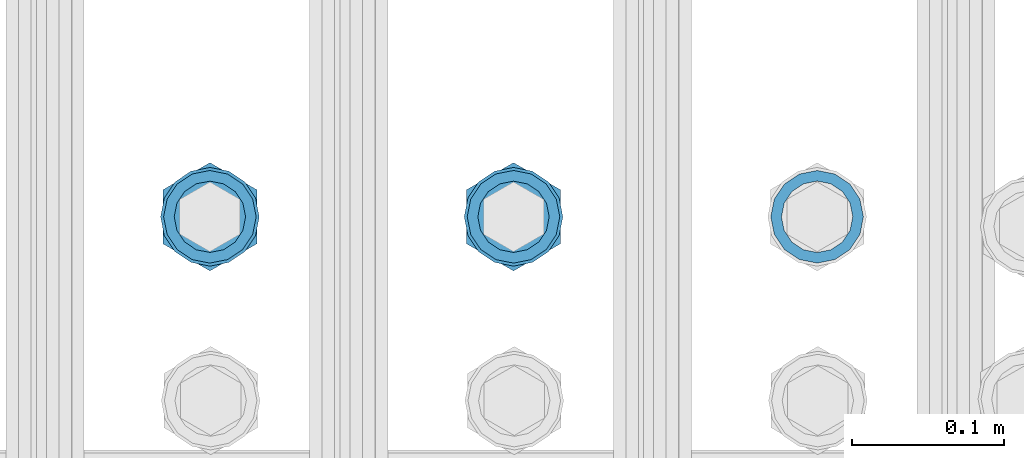
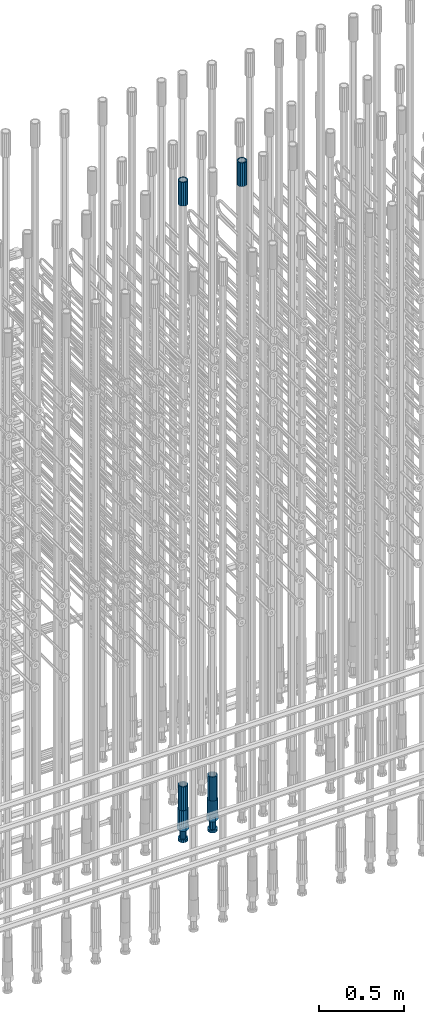
# One storey, part 58 of 177: 6 beams.
"""IFC2X3 building model written with IfcOpenShell, lengths in millimetres."""

from ifc_helpers import new_model, si_unit, frame, origin_with_axes, place, context, subcontext, project, spatial, faceted_brep, material, type_object, element, save


model = new_model("IFC2X3")

# Units and contexts
model_context_1 = context("Model", 3, precision=1e-05, world=origin_with_axes())
model_context_2 = context("Model", 3, precision=1e-05, world=origin_with_axes())
body_context = subcontext(model_context_2, "Body", "Model", "MODEL_VIEW")
ifc_project = project(units=[si_unit("LENGTHUNIT", "METRE", prefix="MILLI"), si_unit("AREAUNIT", "SQUARE_METRE"), si_unit("VOLUMEUNIT", "CUBIC_METRE"), si_unit("MASSUNIT", "GRAM", prefix="KILO"), si_unit("TIMEUNIT", "SECOND"), si_unit("PLANEANGLEUNIT", "RADIAN"), si_unit("SOLIDANGLEUNIT", "STERADIAN"), si_unit("THERMODYNAMICTEMPERATUREUNIT", "DEGREE_CELSIUS"), si_unit("LUMINOUSINTENSITYUNIT", "LUMEN")], contexts=[model_context_1])

# Site, building, storey
site_placement = place(None, origin_with_axes())
site = spatial("IfcSite", under=ifc_project, at=site_placement, CompositionType="ELEMENT")
building_placement = place(site_placement, origin_with_axes())
building = spatial("IfcBuilding", under=site, at=building_placement, Name="Undefined", CompositionType="ELEMENT")
storey_placement = place(building_placement, origin_with_axes())
storey = spatial("IfcBuildingStorey", under=building, at=storey_placement, Name="Undefined", CompositionType="ELEMENT", Elevation=0.0)

# Beams
ifc_material = material(Name="STEEL/S275")
beam_type_1 = type_object("IfcBeamType", PredefinedType="NOTDEFINED")
beam_1_placement = place(storey_placement, frame((2032635.50306268, 6205277.49272666, 23229.9858194793), z_axis=(1.0, 0.0, 0.0), x_axis=(0.0, 0.0, 1.0)))
element("IfcBeam", 1, at=beam_1_placement, inside=storey, type_object=beam_type_1, material=ifc_material, Name="AG40N", context=body_context, shape_type="Brep", body=[
    faceted_brep([(0.0, -23.5000000001164, -9.31322574615479e-10), (0.0, -21.7111690140155, 8.99306066054851), (170.0, -21.7111690140155, 8.99306066054851), (170.0, -23.5, 0.0), (0.0, -16.6170093578839, 16.6170093575493), (170.0, -16.6170093578839, 16.6170093575493), (0.0, -8.99306066057943, 21.7111690137535), (170.0, -8.99306066057943, 21.7111690137535), (0.0, 1.16415321826935e-10, 23.5), (170.0, 0.0, 23.5), (0.0, 8.99306066057943, 21.7111690137535), (170.0, 8.99306066057943, 21.7111690137535), (0.0, 16.6170093578839, 16.6170093575493), (170.0, 16.6170093578839, 16.6170093575493), (0.0, 21.7111690140155, 8.99306066054851), (170.0, 21.7111690140155, 8.99306066054851), (0.0, 23.5000000001164, -9.31322574615479e-10), (170.0, 23.5, 0.0), (0.0, 21.7111690140155, -8.99306066054851), (170.0, 21.7111690140155, -8.99306066054851), (0.0, 16.6170093578839, -16.6170093575493), (170.0, 16.6170093578839, -16.6170093575493), (0.0, 8.99306066057943, -21.7111690137535), (170.0, 8.99306066057943, -21.7111690137535), (0.0, 1.16415321826935e-10, -23.5000000009313), (170.0, 0.0, -23.5), (0.0, -8.99306066057943, -21.7111690137535), (170.0, -8.99306066057943, -21.7111690137535), (0.0, -16.6170093578839, -16.6170093575493), (170.0, -16.6170093578839, -16.6170093575493), (0.0, -21.7111690140155, -8.99306066054851), (170.0, -21.7111690140155, -8.99306066054851), (0.0, -30.5, 0.0), (0.0, -28.1783257415937, -11.6718446873128), (170.0, -28.1783257415937, -11.6718446873128), (170.0, -30.5, 0.0), (0.0, -21.5667568261888, -21.5667568258941), (170.0, -21.5667568261888, -21.5667568258941), (0.0, -11.6718446871346, -28.1783257415518), (170.0, -11.6718446871346, -28.1783257415518), (0.0, 0.0, -30.5), (170.0, 0.0, -30.5), (0.0, 11.6718446871346, -28.1783257415518), (170.0, 11.6718446871346, -28.1783257415518), (0.0, 21.5667568261888, -21.5667568258941), (170.0, 21.5667568261888, -21.5667568258941), (0.0, 28.1783257415937, -11.6718446873128), (170.0, 28.1783257415937, -11.6718446873128), (0.0, 30.5, 0.0), (170.0, 30.5, 0.0), (0.0, 28.1783257415937, 11.6718446873128), (170.0, 28.1783257415937, 11.6718446873128), (0.0, 21.5667568261888, 21.5667568258941), (170.0, 21.5667568261888, 21.5667568258941), (0.0, 11.6718446871346, 28.1783257415518), (170.0, 11.6718446871346, 28.1783257415518), (0.0, 0.0, 30.5), (170.0, 0.0, 30.5), (0.0, -11.6718446871346, 28.1783257415518), (170.0, -11.6718446871346, 28.1783257415518), (0.0, -21.5667568261888, 21.5667568258941), (170.0, -21.5667568261888, 21.5667568258941), (0.0, -28.1783257415937, 11.6718446873128), (170.0, -28.1783257415937, 11.6718446873128)], [[[0, 1, 2, 3]], [[1, 4, 5, 2]], [[4, 6, 7, 5]], [[6, 8, 9, 7]], [[8, 10, 11, 9]], [[10, 12, 13, 11]], [[12, 14, 15, 13]], [[14, 16, 17, 15]], [[16, 18, 19, 17]], [[18, 20, 21, 19]], [[20, 22, 23, 21]], [[22, 24, 25, 23]], [[24, 26, 27, 25]], [[26, 28, 29, 27]], [[28, 30, 31, 29]], [[30, 0, 3, 31]], [[32, 33, 34, 35]], [[33, 36, 37, 34]], [[36, 38, 39, 37]], [[38, 40, 41, 39]], [[40, 42, 43, 41]], [[42, 44, 45, 43]], [[44, 46, 47, 45]], [[46, 48, 49, 47]], [[48, 50, 51, 49]], [[50, 52, 53, 51]], [[52, 54, 55, 53]], [[54, 56, 57, 55]], [[56, 58, 59, 57]], [[58, 60, 61, 59]], [[60, 62, 63, 61]], [[62, 32, 35, 63]], [[37, 39, 41, 43, 45, 47, 49, 51, 53, 55, 57, 59, 61, 63, 35, 34], [5, 7, 9, 11, 13, 15, 17, 19, 21, 23, 25, 27, 29, 31, 3, 2]], [[62, 60, 58, 56, 54, 52, 50, 48, 46, 44, 42, 40, 38, 36, 33, 32], [30, 28, 26, 24, 22, 20, 18, 16, 14, 12, 10, 8, 6, 4, 1, 0]]]),
])
beam_2_placement = place(storey_placement, frame((2032235.5030627, 6205277.49272666, 19060.966800425), z_axis=(-1.0, 0.0, 0.0), x_axis=(0.0, 0.0, -1.0)))
element("IfcBeam", 2, at=beam_2_placement, inside=storey, type_object=beam_type_1, material=ifc_material, Name="AG40N", context=body_context, shape_type="Brep", body=[
    faceted_brep([(0.0, -23.5000000001164, -9.31322574615479e-10), (0.0, -21.7111690140155, 8.99306066054851), (170.0, -21.7111690140155, 8.99306066054851), (170.0, -23.5, 0.0), (0.0, -16.6170093578839, 16.6170093575493), (170.0, -16.6170093578839, 16.6170093575493), (0.0, -8.99306066057943, 21.7111690137535), (170.0, -8.99306066057943, 21.7111690137535), (0.0, 1.16415321826935e-10, 23.5), (170.0, 0.0, 23.5), (0.0, 8.99306066057943, 21.7111690137535), (170.0, 8.99306066057943, 21.7111690137535), (0.0, 16.6170093578839, 16.6170093575493), (170.0, 16.6170093578839, 16.6170093575493), (0.0, 21.7111690140155, 8.99306066054851), (170.0, 21.7111690140155, 8.99306066054851), (0.0, 23.5000000001164, -9.31322574615479e-10), (170.0, 23.5, 0.0), (0.0, 21.7111690140155, -8.99306066054851), (170.0, 21.7111690140155, -8.99306066054851), (0.0, 16.6170093578839, -16.6170093575493), (170.0, 16.6170093578839, -16.6170093575493), (0.0, 8.99306066057943, -21.7111690137535), (170.0, 8.99306066057943, -21.7111690137535), (0.0, 1.16415321826935e-10, -23.5000000009313), (170.0, 0.0, -23.5), (0.0, -8.99306066057943, -21.7111690137535), (170.0, -8.99306066057943, -21.7111690137535), (0.0, -16.6170093578839, -16.6170093575493), (170.0, -16.6170093578839, -16.6170093575493), (0.0, -21.7111690140155, -8.99306066054851), (170.0, -21.7111690140155, -8.99306066054851), (0.0, -30.5, 0.0), (0.0, -28.1783257415937, -11.6718446873128), (170.0, -28.1783257415937, -11.6718446873128), (170.0, -30.5, 0.0), (0.0, -21.5667568261888, -21.5667568258941), (170.0, -21.5667568261888, -21.5667568258941), (0.0, -11.6718446871346, -28.1783257415518), (170.0, -11.6718446871346, -28.1783257415518), (0.0, 0.0, -30.5), (170.0, 0.0, -30.5), (0.0, 11.6718446871346, -28.1783257415518), (170.0, 11.6718446871346, -28.1783257415518), (0.0, 21.5667568261888, -21.5667568258941), (170.0, 21.5667568261888, -21.5667568258941), (0.0, 28.1783257415937, -11.6718446873128), (170.0, 28.1783257415937, -11.6718446873128), (0.0, 30.5, 0.0), (170.0, 30.5, 0.0), (0.0, 28.1783257415937, 11.6718446873128), (170.0, 28.1783257415937, 11.6718446873128), (0.0, 21.5667568261888, 21.5667568258941), (170.0, 21.5667568261888, 21.5667568258941), (0.0, 11.6718446871346, 28.1783257415518), (170.0, 11.6718446871346, 28.1783257415518), (0.0, 0.0, 30.5), (170.0, 0.0, 30.5), (0.0, -11.6718446871346, 28.1783257415518), (170.0, -11.6718446871346, 28.1783257415518), (0.0, -21.5667568261888, 21.5667568258941), (170.0, -21.5667568261888, 21.5667568258941), (0.0, -28.1783257415937, 11.6718446873128), (170.0, -28.1783257415937, 11.6718446873128)], [[[0, 1, 2, 3]], [[1, 4, 5, 2]], [[4, 6, 7, 5]], [[6, 8, 9, 7]], [[8, 10, 11, 9]], [[10, 12, 13, 11]], [[12, 14, 15, 13]], [[14, 16, 17, 15]], [[16, 18, 19, 17]], [[18, 20, 21, 19]], [[20, 22, 23, 21]], [[22, 24, 25, 23]], [[24, 26, 27, 25]], [[26, 28, 29, 27]], [[28, 30, 31, 29]], [[30, 0, 3, 31]], [[32, 33, 34, 35]], [[33, 36, 37, 34]], [[36, 38, 39, 37]], [[38, 40, 41, 39]], [[40, 42, 43, 41]], [[42, 44, 45, 43]], [[44, 46, 47, 45]], [[46, 48, 49, 47]], [[48, 50, 51, 49]], [[50, 52, 53, 51]], [[52, 54, 55, 53]], [[54, 56, 57, 55]], [[56, 58, 59, 57]], [[58, 60, 61, 59]], [[60, 62, 63, 61]], [[62, 32, 35, 63]], [[37, 39, 41, 43, 45, 47, 49, 51, 53, 55, 57, 59, 61, 63, 35, 34], [5, 7, 9, 11, 13, 15, 17, 19, 21, 23, 25, 27, 29, 31, 3, 2]], [[62, 60, 58, 56, 54, 52, 50, 48, 46, 44, 42, 40, 38, 36, 33, 32], [30, 28, 26, 24, 22, 20, 18, 16, 14, 12, 10, 8, 6, 4, 1, 0]]]),
])
beam_3_placement = place(storey_placement, frame((2032235.50306268, 6205277.49272666, 23229.9858194793), z_axis=(1.0, 0.0, 0.0), x_axis=(0.0, 0.0, 1.0)))
element("IfcBeam", 3, at=beam_3_placement, inside=storey, type_object=beam_type_1, material=ifc_material, Name="AG40N", context=body_context, shape_type="Brep", body=[
    faceted_brep([(0.0, -23.5000000001164, -9.31322574615479e-10), (0.0, -21.7111690140155, 8.99306066054851), (170.0, -21.7111690140155, 8.99306066054851), (170.0, -23.5, 0.0), (0.0, -16.6170093578839, 16.6170093575493), (170.0, -16.6170093578839, 16.6170093575493), (0.0, -8.99306066057943, 21.7111690137535), (170.0, -8.99306066057943, 21.7111690137535), (0.0, 1.16415321826935e-10, 23.5), (170.0, 0.0, 23.5), (0.0, 8.99306066057943, 21.7111690137535), (170.0, 8.99306066057943, 21.7111690137535), (0.0, 16.6170093578839, 16.6170093575493), (170.0, 16.6170093578839, 16.6170093575493), (0.0, 21.7111690140155, 8.99306066054851), (170.0, 21.7111690140155, 8.99306066054851), (0.0, 23.5000000001164, -9.31322574615479e-10), (170.0, 23.5, 0.0), (0.0, 21.7111690140155, -8.99306066054851), (170.0, 21.7111690140155, -8.99306066054851), (0.0, 16.6170093578839, -16.6170093575493), (170.0, 16.6170093578839, -16.6170093575493), (0.0, 8.99306066057943, -21.7111690137535), (170.0, 8.99306066057943, -21.7111690137535), (0.0, 1.16415321826935e-10, -23.5000000009313), (170.0, 0.0, -23.5), (0.0, -8.99306066057943, -21.7111690137535), (170.0, -8.99306066057943, -21.7111690137535), (0.0, -16.6170093578839, -16.6170093575493), (170.0, -16.6170093578839, -16.6170093575493), (0.0, -21.7111690140155, -8.99306066054851), (170.0, -21.7111690140155, -8.99306066054851), (0.0, -30.5, 0.0), (0.0, -28.1783257415937, -11.6718446873128), (170.0, -28.1783257415937, -11.6718446873128), (170.0, -30.5, 0.0), (0.0, -21.5667568261888, -21.5667568258941), (170.0, -21.5667568261888, -21.5667568258941), (0.0, -11.6718446871346, -28.1783257415518), (170.0, -11.6718446871346, -28.1783257415518), (0.0, 0.0, -30.5), (170.0, 0.0, -30.5), (0.0, 11.6718446871346, -28.1783257415518), (170.0, 11.6718446871346, -28.1783257415518), (0.0, 21.5667568261888, -21.5667568258941), (170.0, 21.5667568261888, -21.5667568258941), (0.0, 28.1783257415937, -11.6718446873128), (170.0, 28.1783257415937, -11.6718446873128), (0.0, 30.5, 0.0), (170.0, 30.5, 0.0), (0.0, 28.1783257415937, 11.6718446873128), (170.0, 28.1783257415937, 11.6718446873128), (0.0, 21.5667568261888, 21.5667568258941), (170.0, 21.5667568261888, 21.5667568258941), (0.0, 11.6718446871346, 28.1783257415518), (170.0, 11.6718446871346, 28.1783257415518), (0.0, 0.0, 30.5), (170.0, 0.0, 30.5), (0.0, -11.6718446871346, 28.1783257415518), (170.0, -11.6718446871346, 28.1783257415518), (0.0, -21.5667568261888, 21.5667568258941), (170.0, -21.5667568261888, 21.5667568258941), (0.0, -28.1783257415937, 11.6718446873128), (170.0, -28.1783257415937, 11.6718446873128)], [[[0, 1, 2, 3]], [[1, 4, 5, 2]], [[4, 6, 7, 5]], [[6, 8, 9, 7]], [[8, 10, 11, 9]], [[10, 12, 13, 11]], [[12, 14, 15, 13]], [[14, 16, 17, 15]], [[16, 18, 19, 17]], [[18, 20, 21, 19]], [[20, 22, 23, 21]], [[22, 24, 25, 23]], [[24, 26, 27, 25]], [[26, 28, 29, 27]], [[28, 30, 31, 29]], [[30, 0, 3, 31]], [[32, 33, 34, 35]], [[33, 36, 37, 34]], [[36, 38, 39, 37]], [[38, 40, 41, 39]], [[40, 42, 43, 41]], [[42, 44, 45, 43]], [[44, 46, 47, 45]], [[46, 48, 49, 47]], [[48, 50, 51, 49]], [[50, 52, 53, 51]], [[52, 54, 55, 53]], [[54, 56, 57, 55]], [[56, 58, 59, 57]], [[58, 60, 61, 59]], [[60, 62, 63, 61]], [[62, 32, 35, 63]], [[37, 39, 41, 43, 45, 47, 49, 51, 53, 55, 57, 59, 61, 63, 35, 34], [5, 7, 9, 11, 13, 15, 17, 19, 21, 23, 25, 27, 29, 31, 3, 2]], [[62, 60, 58, 56, 54, 52, 50, 48, 46, 44, 42, 40, 38, 36, 33, 32], [30, 28, 26, 24, 22, 20, 18, 16, 14, 12, 10, 8, 6, 4, 1, 0]]]),
])
beam_4_placement = place(storey_placement, frame((2032435.5030627, 6205277.49272665, 19060.9668004261), z_axis=(-1.0, 0.0, 0.0), x_axis=(0.0, 0.0, -1.0)))
element("IfcBeam", 4, at=beam_4_placement, inside=storey, type_object=beam_type_1, material=ifc_material, Name="AG40N", context=body_context, shape_type="Brep", body=[
    faceted_brep([(0.0, -23.5000000001164, -9.31322574615479e-10), (0.0, -21.7111690140155, 8.99306066054851), (170.0, -21.7111690140155, 8.99306066054851), (170.0, -23.5, 0.0), (0.0, -16.6170093578839, 16.6170093575493), (170.0, -16.6170093578839, 16.6170093575493), (0.0, -8.99306066057943, 21.7111690137535), (170.0, -8.99306066057943, 21.7111690137535), (0.0, 1.16415321826935e-10, 23.5), (170.0, 0.0, 23.5), (0.0, 8.99306066057943, 21.7111690137535), (170.0, 8.99306066057943, 21.7111690137535), (0.0, 16.6170093578839, 16.6170093575493), (170.0, 16.6170093578839, 16.6170093575493), (0.0, 21.7111690140155, 8.99306066054851), (170.0, 21.7111690140155, 8.99306066054851), (0.0, 23.5000000001164, -9.31322574615479e-10), (170.0, 23.5, 0.0), (0.0, 21.7111690140155, -8.99306066054851), (170.0, 21.7111690140155, -8.99306066054851), (0.0, 16.6170093578839, -16.6170093575493), (170.0, 16.6170093578839, -16.6170093575493), (0.0, 8.99306066057943, -21.7111690137535), (170.0, 8.99306066057943, -21.7111690137535), (0.0, 1.16415321826935e-10, -23.5000000009313), (170.0, 0.0, -23.5), (0.0, -8.99306066057943, -21.7111690137535), (170.0, -8.99306066057943, -21.7111690137535), (0.0, -16.6170093578839, -16.6170093575493), (170.0, -16.6170093578839, -16.6170093575493), (0.0, -21.7111690140155, -8.99306066054851), (170.0, -21.7111690140155, -8.99306066054851), (0.0, -30.5, 0.0), (0.0, -28.1783257415937, -11.6718446873128), (170.0, -28.1783257415937, -11.6718446873128), (170.0, -30.5, 0.0), (0.0, -21.5667568261888, -21.5667568258941), (170.0, -21.5667568261888, -21.5667568258941), (0.0, -11.6718446871346, -28.1783257415518), (170.0, -11.6718446871346, -28.1783257415518), (0.0, 0.0, -30.5), (170.0, 0.0, -30.5), (0.0, 11.6718446871346, -28.1783257415518), (170.0, 11.6718446871346, -28.1783257415518), (0.0, 21.5667568261888, -21.5667568258941), (170.0, 21.5667568261888, -21.5667568258941), (0.0, 28.1783257415937, -11.6718446873128), (170.0, 28.1783257415937, -11.6718446873128), (0.0, 30.5, 0.0), (170.0, 30.5, 0.0), (0.0, 28.1783257415937, 11.6718446873128), (170.0, 28.1783257415937, 11.6718446873128), (0.0, 21.5667568261888, 21.5667568258941), (170.0, 21.5667568261888, 21.5667568258941), (0.0, 11.6718446871346, 28.1783257415518), (170.0, 11.6718446871346, 28.1783257415518), (0.0, 0.0, 30.5), (170.0, 0.0, 30.5), (0.0, -11.6718446871346, 28.1783257415518), (170.0, -11.6718446871346, 28.1783257415518), (0.0, -21.5667568261888, 21.5667568258941), (170.0, -21.5667568261888, 21.5667568258941), (0.0, -28.1783257415937, 11.6718446873128), (170.0, -28.1783257415937, 11.6718446873128)], [[[0, 1, 2, 3]], [[1, 4, 5, 2]], [[4, 6, 7, 5]], [[6, 8, 9, 7]], [[8, 10, 11, 9]], [[10, 12, 13, 11]], [[12, 14, 15, 13]], [[14, 16, 17, 15]], [[16, 18, 19, 17]], [[18, 20, 21, 19]], [[20, 22, 23, 21]], [[22, 24, 25, 23]], [[24, 26, 27, 25]], [[26, 28, 29, 27]], [[28, 30, 31, 29]], [[30, 0, 3, 31]], [[32, 33, 34, 35]], [[33, 36, 37, 34]], [[36, 38, 39, 37]], [[38, 40, 41, 39]], [[40, 42, 43, 41]], [[42, 44, 45, 43]], [[44, 46, 47, 45]], [[46, 48, 49, 47]], [[48, 50, 51, 49]], [[50, 52, 53, 51]], [[52, 54, 55, 53]], [[54, 56, 57, 55]], [[56, 58, 59, 57]], [[58, 60, 61, 59]], [[60, 62, 63, 61]], [[62, 32, 35, 63]], [[37, 39, 41, 43, 45, 47, 49, 51, 53, 55, 57, 59, 61, 63, 35, 34], [5, 7, 9, 11, 13, 15, 17, 19, 21, 23, 25, 27, 29, 31, 3, 2]], [[62, 60, 58, 56, 54, 52, 50, 48, 46, 44, 42, 40, 38, 36, 33, 32], [30, 28, 26, 24, 22, 20, 18, 16, 14, 12, 10, 8, 6, 4, 1, 0]]]),
])
beam_type_2 = type_object("IfcBeamType", Name="ROD65", PredefinedType="NOTDEFINED")
beam_5_placement = place(storey_placement, frame((2032235.50306269, 6205277.49272666, 18890.966800425), z_axis=(-1.0, 0.0, 0.0), x_axis=(0.0, 0.0, -1.0)))
element("IfcBeam", 5, at=beam_5_placement, inside=storey, type_object=beam_type_2, material=ifc_material, Name="AGB40", ObjectType="ROD65", context=body_context, shape_type="Brep", body=[
    faceted_brep([(117.0, 8.17543110251427, 30.873805644922), (117.0, 17.8250000001863, 30.873805644922), (117.0, 22.0056958701462, 23.6326279877685), (117.0, 12.4372115517035, 30.0260848065373), (117.0, -17.8250000001863, 30.873805644922), (150.200000000186, -17.8250000001863, 30.873805644922), (150.200000000186, 17.8250000001863, 30.873805644922), (117.0, -8.17543110251427, 30.873805644922), (117.0, -12.4372115517035, 30.0260848065373), (117.0, -22.0056958701462, 23.6326279877685), (117.0, -35.6500000003725, 0.0), (150.200000000186, -35.6500000003725, 0.0), (117.0, -30.8443150008097, 8.32369058486074), (117.0, -32.5, 0.0), (117.0, -30.8443150008097, -8.32369058462791), (117.0, -17.8250000001863, -30.873805644922), (150.200000000186, -17.8250000001863, -30.873805644922), (117.0, -22.0056958701462, -23.6326279877685), (117.0, -12.4372115517035, -30.0260848065373), (117.0, -8.17543110251427, -30.873805644922), (117.0, 17.8250000001863, -30.873805644922), (150.200000000186, 17.8250000001863, -30.873805644922), (117.0, 8.17543110251427, -30.873805644922), (117.0, 22.0056958701462, -23.6326279877685), (117.0, 12.4372115517035, -30.0260848065373), (117.0, 35.6500000003725, 0.0), (150.200000000186, 35.6500000003725, 0.0), (117.0, 30.8443150008097, -8.32369058486074), (117.0, 30.8443150008097, 8.32369058462791), (117.0, 32.5, 0.0), (0.0, -22.9809703892097, 22.9809703885621), (0.0, -30.0260848058388, 12.4372115518636), (117.0, -30.0260848067701, 12.4372115519363), (117.0, -22.9809703882784, 22.9809703885112), (-2.3283064365387e-10, 22.9809703892097, -22.9809703885639), (-4.65661287307739e-10, 30.0260848077014, -12.4372115518672), (117.0, 30.0260848067701, -12.4372115519363), (117.0, 22.9809703882784, -22.9809703885112), (-2.3283064365387e-10, -30.0260848067701, -12.4372115518672), (-2.3283064365387e-10, -22.9809703892097, -22.9809703885621), (117.0, -22.9809703882784, -22.9809703885112), (117.0, -30.0260848067701, -12.4372115519363), (-2.3283064365387e-10, -12.4372115507722, 30.0260848066137), (-2.3283064365387e-10, 9.31322574615479e-10, 32.4999999999982), (-2.3283064365387e-10, 12.4372115526348, 30.0260848066137), (0.0, 22.9809703892097, 22.9809703885621), (-2.3283064365387e-10, 30.0260848077014, 12.4372115518636), (-2.3283064365387e-10, 32.5, 0.0), (-2.3283064365387e-10, 12.4372115526348, -30.0260848066173), (-2.3283064365387e-10, 9.31322574615479e-10, -32.5), (-2.3283064365387e-10, -12.4372115517035, -30.0260848066173), (-4.65661287307739e-10, -32.4999999990687, -1.81898940354586e-12), (117.0, 22.9809703882784, 22.9809703885112), (117.0, 30.0260848067701, 12.4372115519363), (117.0, 0.0, -32.5), (117.0, 0.0, 32.5), (150.200000000186, 10.5, -18.1865334794857), (150.200000000186, 0.0, -21.0), (150.200000000186, -10.5, -18.1865334794857), (150.200000000186, -18.18653347902, -10.5), (150.200000000186, -21.0, 0.0), (150.200000000186, -18.18653347902, 10.5), (150.200000000186, -10.5, 18.1865334794857), (150.200000000186, 0.0, 21.0), (150.200000000186, 10.5, 18.1865334794857), (150.200000000186, 18.18653347902, 10.5), (150.200000000186, 21.0, 0.0), (150.200000000186, 18.18653347902, -10.5), (210.980000000447, -10.5, -18.1865334794857), (210.980000000447, 0.0, -21.0), (210.980000000447, -18.18653347902, -10.5), (210.980000000447, -21.0, 0.0), (210.980000000447, -18.18653347902, 10.5), (210.980000000447, -10.5, 18.1865334794857), (210.980000000447, 0.0, 21.0), (210.980000000447, 10.5, 18.1865334794857), (210.980000000447, 18.18653347902, 10.5), (210.980000000447, 21.0, 0.0), (210.980000000447, 18.18653347902, -10.5), (210.980000000447, 10.5, -18.1865334794857), (211.001368442696, -27.7269937992096, -11.491116326768), (211.003082550167, -21.2238094303757, -21.223815418547), (231.002518367059, -21.2131944671273, -21.2132004550658), (231.000804259587, -27.7163788359612, -11.4805013632867), (211.001368440451, -11.4911085031927, -27.7269970395137), (231.000804257343, -11.4804935399443, -27.7163820760325), (210.996487071217, -0.0106065049767494, -30.0106107392348), (230.995922888109, 8.45827162265778e-06, -29.9999957757536), (210.989181586672, 11.46989420522, -27.7269970329944), (230.988617403564, 11.4805091684684, -27.7163820695132), (210.980564180623, 21.2025914648548, -21.2238154064398), (230.979999997515, 21.2132064281031, -21.2132004429586), (210.971946775022, 27.7057703435421, -11.4911163107026), (230.971382591913, 27.7163853067905, -11.4805013472214), (210.96464129175, 29.9893808094785, -0.0106149562634528), (230.964077108642, 29.9999957727268, 7.21774995326996e-09), (210.959759924415, 27.7057638689876, 11.4698863970116), (230.959195741307, 27.7163788322359, 11.4805013604928), (210.958045816944, 21.2025795001537, 21.2025854887906), (230.957481633835, 21.213194463402, 21.2132004522718), (210.95975992666, 11.4698785729706, 27.7057671097573), (230.959195743551, 11.480493536219, 27.7163820732385), (210.964641295894, -0.010623425245285, 29.9893808094785), (230.964077112785, -8.46199691295624e-06, 29.9999957729597), (210.971946780439, -11.4911241354421, 27.705767103238), (230.97138259733, -11.4805091721937, 27.7163820667192), (210.980564186488, -21.2238213950768, 21.2025854766835), (230.980000003379, -21.2132064318284, 21.2132004401647), (210.989181592089, -27.7270002737641, 11.4698863809463), (230.988617408981, -27.7163853105158, 11.4805013444275), (210.996487075361, -30.0106107397005, -0.0106149734929204), (230.995922892253, -29.9999957764521, -1.00117176771164e-08)], [[[0, 1, 2, 3]], [[4, 5, 6, 1, 0, 7]], [[4, 7, 8, 9]], [[10, 11, 5, 4, 9, 12]], [[10, 12, 13, 14]], [[15, 16, 11, 10, 14, 17]], [[15, 17, 18, 19]], [[20, 21, 16, 15, 19, 22]], [[23, 20, 22, 24]], [[25, 26, 21, 20, 23, 27]], [[28, 25, 27, 29]], [[30, 31, 32, 33]], [[34, 35, 36, 37]], [[38, 39, 40, 41]], [[31, 30, 42, 43, 44, 45, 46, 47, 35, 34, 48, 49, 50, 39, 38, 51]], [[46, 45, 52, 53]], [[29, 47, 46, 53, 28]], [[27, 36, 35, 47, 29]], [[23, 37, 36, 27]], [[24, 48, 34, 37, 23]], [[22, 54, 49, 48, 24]], [[19, 54, 22]], [[18, 50, 49, 54, 19]], [[17, 40, 39, 50, 18]], [[14, 41, 40, 17]], [[13, 51, 38, 41, 14]], [[12, 32, 31, 51, 13]], [[9, 33, 32, 12]], [[8, 42, 30, 33, 9]], [[7, 55, 43, 42, 8]], [[0, 55, 7]], [[3, 44, 43, 55, 0]], [[2, 52, 45, 44, 3]], [[28, 53, 52, 2]], [[1, 6, 26, 25, 28, 2]], [[5, 11, 16, 21, 26, 6], [56, 57, 58, 59, 60, 61, 62, 63, 64, 65, 66, 67]], [[68, 58, 57, 69]], [[70, 59, 58, 68]], [[71, 60, 59, 70]], [[72, 61, 60, 71]], [[73, 62, 61, 72]], [[74, 63, 62, 73]], [[75, 64, 63, 74]], [[76, 65, 64, 75]], [[77, 66, 65, 76]], [[78, 67, 66, 77]], [[79, 56, 67, 78]], [[69, 57, 56, 79]], [[80, 81, 82, 83]], [[81, 84, 85, 82]], [[84, 86, 87, 85]], [[86, 88, 89, 87]], [[88, 90, 91, 89]], [[90, 92, 93, 91]], [[92, 94, 95, 93]], [[94, 96, 97, 95]], [[96, 98, 99, 97]], [[98, 100, 101, 99]], [[100, 102, 103, 101]], [[102, 104, 105, 103]], [[104, 106, 107, 105]], [[106, 108, 109, 107]], [[108, 110, 111, 109]], [[82, 85, 87, 89, 91, 93, 95, 97, 99, 101, 103, 105, 107, 109, 111, 83]], [[110, 80, 83, 111]], [[108, 106, 104, 102, 100, 98, 96, 94, 92, 90, 88, 86, 84, 81, 80, 110], [78, 77, 76, 75, 74, 73, 72, 71, 70, 68, 69, 79]]]),
])
beam_6_placement = place(storey_placement, frame((2032435.50306269, 6205277.49272665, 18890.9668004261), z_axis=(-1.0, 0.0, 0.0), x_axis=(0.0, 0.0, -1.0)))
element("IfcBeam", 6, at=beam_6_placement, inside=storey, type_object=beam_type_2, material=ifc_material, Name="AGB40", ObjectType="ROD65", context=body_context, shape_type="Brep", body=[
    faceted_brep([(117.0, 8.17543110251427, 30.873805644922), (117.0, 17.8250000001863, 30.873805644922), (117.0, 22.0056958701462, 23.6326279877685), (117.0, 12.4372115517035, 30.0260848065373), (117.0, -17.8250000001863, 30.873805644922), (150.200000000186, -17.8250000001863, 30.873805644922), (150.200000000186, 17.8250000001863, 30.873805644922), (117.0, -8.17543110251427, 30.873805644922), (117.0, -12.4372115517035, 30.0260848065373), (117.0, -22.0056958701462, 23.6326279877685), (117.0, -35.6500000003725, 0.0), (150.200000000186, -35.6500000003725, 0.0), (117.0, -30.8443150008097, 8.32369058486074), (117.0, -32.5, 0.0), (117.0, -30.8443150008097, -8.32369058462791), (117.0, -17.8250000001863, -30.873805644922), (150.200000000186, -17.8250000001863, -30.873805644922), (117.0, -22.0056958701462, -23.6326279877685), (117.0, -12.4372115517035, -30.0260848065373), (117.0, -8.17543110251427, -30.873805644922), (117.0, 17.8250000001863, -30.873805644922), (150.200000000186, 17.8250000001863, -30.873805644922), (117.0, 8.17543110251427, -30.873805644922), (117.0, 22.0056958701462, -23.6326279877685), (117.0, 12.4372115517035, -30.0260848065373), (117.0, 35.6500000003725, 0.0), (150.200000000186, 35.6500000003725, 0.0), (117.0, 30.8443150008097, -8.32369058486074), (117.0, 30.8443150008097, 8.32369058462791), (117.0, 32.5, 0.0), (0.0, -22.9809703892097, 22.9809703885621), (0.0, -30.0260848058388, 12.4372115518636), (117.0, -30.0260848067701, 12.4372115519363), (117.0, -22.9809703882784, 22.9809703885112), (-2.3283064365387e-10, 22.9809703892097, -22.9809703885639), (-4.65661287307739e-10, 30.0260848077014, -12.4372115518672), (117.0, 30.0260848067701, -12.4372115519363), (117.0, 22.9809703882784, -22.9809703885112), (-2.3283064365387e-10, -30.0260848067701, -12.4372115518672), (-2.3283064365387e-10, -22.9809703892097, -22.9809703885621), (117.0, -22.9809703882784, -22.9809703885112), (117.0, -30.0260848067701, -12.4372115519363), (-2.3283064365387e-10, -12.4372115507722, 30.0260848066137), (-2.3283064365387e-10, 9.31322574615479e-10, 32.4999999999982), (-2.3283064365387e-10, 12.4372115526348, 30.0260848066137), (0.0, 22.9809703892097, 22.9809703885621), (-2.3283064365387e-10, 30.0260848077014, 12.4372115518636), (-2.3283064365387e-10, 32.5, 0.0), (-2.3283064365387e-10, 12.4372115526348, -30.0260848066173), (-2.3283064365387e-10, 9.31322574615479e-10, -32.5), (-2.3283064365387e-10, -12.4372115517035, -30.0260848066173), (-4.65661287307739e-10, -32.4999999990687, -1.81898940354586e-12), (117.0, 22.9809703882784, 22.9809703885112), (117.0, 30.0260848067701, 12.4372115519363), (117.0, 0.0, -32.5), (117.0, 0.0, 32.5), (150.200000000186, 10.5, -18.1865334794857), (150.200000000186, 0.0, -21.0), (150.200000000186, -10.5, -18.1865334794857), (150.200000000186, -18.18653347902, -10.5), (150.200000000186, -21.0, 0.0), (150.200000000186, -18.18653347902, 10.5), (150.200000000186, -10.5, 18.1865334794857), (150.200000000186, 0.0, 21.0), (150.200000000186, 10.5, 18.1865334794857), (150.200000000186, 18.18653347902, 10.5), (150.200000000186, 21.0, 0.0), (150.200000000186, 18.18653347902, -10.5), (210.980000000447, -10.5, -18.1865334794857), (210.980000000447, 0.0, -21.0), (210.980000000447, -18.18653347902, -10.5), (210.980000000447, -21.0, 0.0), (210.980000000447, -18.18653347902, 10.5), (210.980000000447, -10.5, 18.1865334794857), (210.980000000447, 0.0, 21.0), (210.980000000447, 10.5, 18.1865334794857), (210.980000000447, 18.18653347902, 10.5), (210.980000000447, 21.0, 0.0), (210.980000000447, 18.18653347902, -10.5), (210.980000000447, 10.5, -18.1865334794857), (211.001368442696, -27.7269937992096, -11.491116326768), (211.003082550167, -21.2238094303757, -21.223815418547), (231.002518367059, -21.2131944671273, -21.2132004550658), (231.000804259587, -27.7163788359612, -11.4805013632867), (211.001368440451, -11.4911085031927, -27.7269970395137), (231.000804257343, -11.4804935399443, -27.7163820760325), (210.996487071217, -0.0106065049767494, -30.0106107392348), (230.995922888109, 8.45827162265778e-06, -29.9999957757536), (210.989181586672, 11.46989420522, -27.7269970329944), (230.988617403564, 11.4805091684684, -27.7163820695132), (210.980564180623, 21.2025914648548, -21.2238154064398), (230.979999997515, 21.2132064281031, -21.2132004429586), (210.971946775022, 27.7057703435421, -11.4911163107026), (230.971382591913, 27.7163853067905, -11.4805013472214), (210.96464129175, 29.9893808094785, -0.0106149562634528), (230.964077108642, 29.9999957727268, 7.21774995326996e-09), (210.959759924415, 27.7057638689876, 11.4698863970116), (230.959195741307, 27.7163788322359, 11.4805013604928), (210.958045816944, 21.2025795001537, 21.2025854887906), (230.957481633835, 21.213194463402, 21.2132004522718), (210.95975992666, 11.4698785729706, 27.7057671097573), (230.959195743551, 11.480493536219, 27.7163820732385), (210.964641295894, -0.010623425245285, 29.9893808094785), (230.964077112785, -8.46199691295624e-06, 29.9999957729597), (210.971946780439, -11.4911241354421, 27.705767103238), (230.97138259733, -11.4805091721937, 27.7163820667192), (210.980564186488, -21.2238213950768, 21.2025854766835), (230.980000003379, -21.2132064318284, 21.2132004401647), (210.989181592089, -27.7270002737641, 11.4698863809463), (230.988617408981, -27.7163853105158, 11.4805013444275), (210.996487075361, -30.0106107397005, -0.0106149734929204), (230.995922892253, -29.9999957764521, -1.00117176771164e-08)], [[[0, 1, 2, 3]], [[4, 5, 6, 1, 0, 7]], [[4, 7, 8, 9]], [[10, 11, 5, 4, 9, 12]], [[10, 12, 13, 14]], [[15, 16, 11, 10, 14, 17]], [[15, 17, 18, 19]], [[20, 21, 16, 15, 19, 22]], [[23, 20, 22, 24]], [[25, 26, 21, 20, 23, 27]], [[28, 25, 27, 29]], [[30, 31, 32, 33]], [[34, 35, 36, 37]], [[38, 39, 40, 41]], [[31, 30, 42, 43, 44, 45, 46, 47, 35, 34, 48, 49, 50, 39, 38, 51]], [[46, 45, 52, 53]], [[29, 47, 46, 53, 28]], [[27, 36, 35, 47, 29]], [[23, 37, 36, 27]], [[24, 48, 34, 37, 23]], [[22, 54, 49, 48, 24]], [[19, 54, 22]], [[18, 50, 49, 54, 19]], [[17, 40, 39, 50, 18]], [[14, 41, 40, 17]], [[13, 51, 38, 41, 14]], [[12, 32, 31, 51, 13]], [[9, 33, 32, 12]], [[8, 42, 30, 33, 9]], [[7, 55, 43, 42, 8]], [[0, 55, 7]], [[3, 44, 43, 55, 0]], [[2, 52, 45, 44, 3]], [[28, 53, 52, 2]], [[1, 6, 26, 25, 28, 2]], [[5, 11, 16, 21, 26, 6], [56, 57, 58, 59, 60, 61, 62, 63, 64, 65, 66, 67]], [[68, 58, 57, 69]], [[70, 59, 58, 68]], [[71, 60, 59, 70]], [[72, 61, 60, 71]], [[73, 62, 61, 72]], [[74, 63, 62, 73]], [[75, 64, 63, 74]], [[76, 65, 64, 75]], [[77, 66, 65, 76]], [[78, 67, 66, 77]], [[79, 56, 67, 78]], [[69, 57, 56, 79]], [[80, 81, 82, 83]], [[81, 84, 85, 82]], [[84, 86, 87, 85]], [[86, 88, 89, 87]], [[88, 90, 91, 89]], [[90, 92, 93, 91]], [[92, 94, 95, 93]], [[94, 96, 97, 95]], [[96, 98, 99, 97]], [[98, 100, 101, 99]], [[100, 102, 103, 101]], [[102, 104, 105, 103]], [[104, 106, 107, 105]], [[106, 108, 109, 107]], [[108, 110, 111, 109]], [[82, 85, 87, 89, 91, 93, 95, 97, 99, 101, 103, 105, 107, 109, 111, 83]], [[110, 80, 83, 111]], [[108, 106, 104, 102, 100, 98, 96, 94, 92, 90, 88, 86, 84, 81, 80, 110], [78, 77, 76, 75, 74, 73, 72, 71, 70, 68, 69, 79]]]),
])

save(model, "model.ifc")
